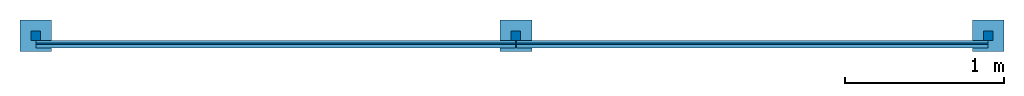
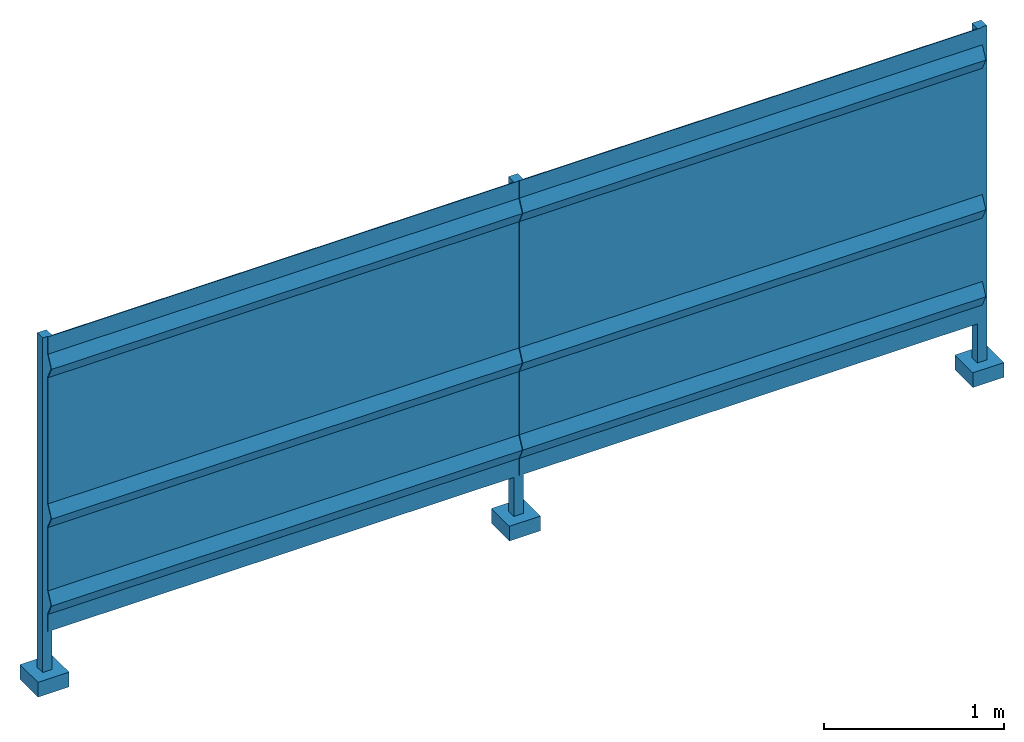
# One storey: 1 wall.
"""IFC2X3 building model written with IfcOpenShell, lengths in millimetres."""

from ifc_helpers import new_model, entity, si_unit, converted_unit, derived_unit, direction, frame, origin, place, context, subcontext, project, spatial, faceted_brep, material, type_object, element, save


model = new_model("IFC2X3")

# Units and contexts
model_context = context("Model", 3, precision=0.01, world=origin(), true_north=direction((6.12303176911189e-17, 1.0)))
body_context = subcontext(model_context, "Body", "Model", "MODEL_VIEW")
ifc_project = project(units=[si_unit("LENGTHUNIT", "METRE", prefix="MILLI"), si_unit("AREAUNIT", "SQUARE_METRE"), si_unit("VOLUMEUNIT", "CUBIC_METRE"), converted_unit("PLANEANGLEUNIT", "DEGREE", entity("IfcRatioMeasure", 0.0174532925199433), si_unit("PLANEANGLEUNIT", "RADIAN"), dimensions=[0, 0, 0, 0, 0, 0, 0]), si_unit("MASSUNIT", "GRAM", prefix="KILO"), derived_unit("MASSDENSITYUNIT", [(si_unit("MASSUNIT", "GRAM", prefix="KILO"), 1), (si_unit("LENGTHUNIT", "METRE"), -3)]), si_unit("TIMEUNIT", "SECOND"), si_unit("FREQUENCYUNIT", "HERTZ"), si_unit("THERMODYNAMICTEMPERATUREUNIT", "DEGREE_CELSIUS"), derived_unit("THERMALTRANSMITTANCEUNIT", [(si_unit("MASSUNIT", "GRAM", prefix="KILO"), 1), (si_unit("THERMODYNAMICTEMPERATUREUNIT", "KELVIN"), -1), (si_unit("TIMEUNIT", "SECOND"), -3)]), derived_unit("VOLUMETRICFLOWRATEUNIT", [(si_unit("LENGTHUNIT", "METRE"), 3), (si_unit("TIMEUNIT", "SECOND"), -1)]), si_unit("ELECTRICCURRENTUNIT", "AMPERE"), si_unit("ELECTRICVOLTAGEUNIT", "VOLT"), si_unit("POWERUNIT", "WATT"), si_unit("FORCEUNIT", "NEWTON", prefix="KILO"), si_unit("ILLUMINANCEUNIT", "LUX"), si_unit("LUMINOUSFLUXUNIT", "LUMEN"), si_unit("LUMINOUSINTENSITYUNIT", "CANDELA"), derived_unit("USERDEFINED", [(si_unit("MASSUNIT", "GRAM", prefix="KILO"), -1), (si_unit("LENGTHUNIT", "METRE"), -2), (si_unit("TIMEUNIT", "SECOND"), 3), (si_unit("LUMINOUSFLUXUNIT", "LUMEN"), 1)]), derived_unit("LINEARVELOCITYUNIT", [(si_unit("LENGTHUNIT", "METRE"), 1), (si_unit("TIMEUNIT", "SECOND"), -1)]), si_unit("PRESSUREUNIT", "PASCAL"), derived_unit("USERDEFINED", [(si_unit("LENGTHUNIT", "METRE"), -2), (si_unit("MASSUNIT", "GRAM", prefix="KILO"), 1), (si_unit("TIMEUNIT", "SECOND"), -2)])], contexts=[model_context])

# Site, building, storey
site_placement = place(None, origin())
site = spatial("IfcSite", under=ifc_project, at=site_placement, CompositionType="ELEMENT")
building_placement = place(site_placement, origin())
building = spatial("IfcBuilding", under=site, at=building_placement, CompositionType="ELEMENT")
storey_placement = place(building_placement, origin())
storey = spatial("IfcBuildingStorey", under=building, at=storey_placement, Name="Level 1", CompositionType="ELEMENT", Elevation=0.0)

# Wall
ifc_material = material()
wall_type = type_object("IfcWallType", PredefinedType="NOTDEFINED", material=ifc_material)
wall_placement = place(storey_placement, frame((-100.0, -100.0, -300.0)))
element("IfcWall", 1, at=wall_placement, inside=storey, type_object=wall_type, material=ifc_material, context=body_context, shape_type="Brep", body=[
    faceted_brep([(3123.0, 64.0, 487.0), (3123.0, 64.0, 370.0), (3123.0, 70.0, 370.0), (3123.0, 70.0, 488.368629060399), (3123.0, 31.6586527353121, 567.0), (3123.0, 70.0, 645.63137093946), (3123.0, 70.0, 1078.3686290604), (3123.0, 31.6586527353121, 1157.0), (3123.0, 70.0, 1235.63137093946), (3123.0, 70.0, 2094.3686290604), (3123.0, 31.6586527353121, 2173.0), (3123.0, 70.0, 2251.63137093946), (3123.0, 70.0, 2370.0), (3123.0, 64.0, 2370.0), (3123.0, 64.0, 2253.0), (3123.0, 25.0, 2173.0), (3123.0, 64.0, 2093.0), (3123.0, 64.0, 1237.0), (3123.0, 25.0, 1157.0), (3123.0, 64.0, 1077.0), (3123.0, 64.0, 647.0), (3123.0, 25.0, 567.0), (102.0, 64.0, 487.0), (102.0, 64.0, 370.0), (102.0, 70.0, 370.0), (102.0, 70.0, 488.368629060399), (102.0, 31.6586527353121, 567.0), (102.0, 70.0, 645.63137093946), (102.0, 70.0, 1078.3686290604), (102.0, 31.6586527353121, 1157.0), (102.0, 70.0, 1235.63137093946), (102.0, 70.0, 2094.3686290604), (102.0, 64.0, 2093.0), (102.0, 64.0, 1237.0), (102.0, 25.0, 1157.0), (102.0, 64.0, 1077.0), (102.0, 64.0, 647.0), (102.0, 25.0, 567.0), (102.0, 25.0, 2173.0), (102.0, 64.0, 2253.0), (102.0, 64.0, 2370.0), (102.0, 70.0, 2370.0), (102.0, 70.0, 2251.63137093946), (102.0, 31.6586527353121, 2173.0)], [[[0, 1, 2, 3, 4, 5, 6, 7, 8, 9, 10, 11, 12, 13, 14, 15, 16, 17, 18, 19, 20, 21]], [[1, 0, 22, 23]], [[2, 1, 23, 24]], [[3, 2, 24, 25]], [[4, 3, 25, 26]], [[5, 4, 26, 27]], [[6, 5, 27, 28]], [[7, 6, 28, 29]], [[8, 7, 29, 30]], [[9, 8, 30, 31]], [[17, 16, 32, 33]], [[18, 17, 33, 34]], [[19, 18, 34, 35]], [[20, 19, 35, 36]], [[21, 20, 36, 37]], [[0, 21, 37, 22]], [[22, 37, 36, 35, 34, 33, 32, 38, 39, 40, 41, 42, 43, 31, 30, 29, 28, 27, 26, 25, 24, 23]], [[11, 10, 43, 42]], [[12, 11, 42, 41]], [[13, 12, 41, 40]], [[14, 13, 40, 39]], [[15, 14, 39, 38]], [[10, 9, 31, 43]], [[16, 15, 38, 32]]]),
    faceted_brep([(200.0, 200.0, 100.0), (0.0, 200.0, 100.0), (0.0, 0.0, 100.0), (200.0, 0.0, 100.0), (200.0, 200.0, 0.0), (200.0, 0.0, 0.0), (0.0, 0.0, 0.0), (0.0, 200.0, 0.0)], [[[0, 1, 2, 3]], [[4, 5, 6, 7]], [[1, 0, 4, 7]], [[2, 1, 7, 6]], [[3, 2, 6, 5]], [[0, 3, 5, 4]]]),
    faceted_brep([(130.0, 130.0, 100.0), (130.0, 70.0, 100.0), (70.0, 70.0, 100.0), (70.0, 130.0, 100.0), (130.0, 130.0, 2370.0), (130.0, 70.0, 2370.0), (70.0, 70.0, 2370.0), (70.0, 130.0, 2370.0)], [[[0, 1, 2, 3]], [[4, 5, 1, 0]], [[5, 6, 2, 1]], [[6, 7, 3, 2]], [[7, 4, 0, 3]], [[4, 7, 6, 5]]]),
    faceted_brep([(3225.0, 200.0, 100.0), (3025.0, 200.0, 100.0), (3025.0, 0.0, 100.0), (3225.0, 0.0, 100.0), (3225.0, 200.0, 0.0), (3225.0, 0.0, 0.0), (3025.0, 0.0, 0.0), (3025.0, 200.0, 0.0)], [[[0, 1, 2, 3]], [[4, 5, 6, 7]], [[1, 0, 4, 7]], [[2, 1, 7, 6]], [[3, 2, 6, 5]], [[0, 3, 5, 4]]]),
    faceted_brep([(3155.0, 130.0, 100.0), (3155.0, 70.0, 100.0), (3095.0, 70.0, 100.0), (3095.0, 130.0, 100.0), (3155.0, 130.0, 2370.0), (3155.0, 70.0, 2370.0), (3095.0, 70.0, 2370.0), (3095.0, 130.0, 2370.0)], [[[0, 1, 2, 3]], [[4, 5, 1, 0]], [[5, 6, 2, 1]], [[6, 7, 3, 2]], [[7, 4, 0, 3]], [[4, 7, 6, 5]]]),
    faceted_brep([(6098.0, 64.0, 487.0), (6098.0, 64.0, 370.0), (6098.0, 70.0, 370.0), (6098.0, 70.0, 488.368629060376), (6098.0, 31.6586527352925, 567.0), (6098.0, 70.0, 645.631370939437), (6098.0, 70.0, 1078.36862906038), (6098.0, 31.6586527352925, 1157.0), (6098.0, 70.0, 1235.63137093943), (6098.0, 70.0, 2094.36862906038), (6098.0, 31.6586527352925, 2173.0), (6098.0, 70.0, 2251.63137093944), (6098.0, 70.0, 2370.0), (6098.0, 64.0, 2370.0), (6098.0, 64.0, 2253.0), (6098.0, 25.0, 2173.0), (6098.0, 64.0, 2093.0), (6098.0, 64.0, 1237.0), (6098.0, 25.0, 1157.0), (6098.0, 64.0, 1077.0), (6098.0, 64.0, 647.0), (6098.0, 25.0, 567.0), (3127.0, 64.0, 487.0), (3127.0, 64.0, 370.0), (3127.0, 70.0, 370.0), (3127.0, 70.0, 488.368629060376), (3127.0, 31.6586527352925, 567.0), (3127.0, 70.0, 645.631370939437), (3127.0, 70.0, 1078.36862906038), (3127.0, 31.6586527352925, 1157.0), (3127.0, 70.0, 1235.63137093943), (3127.0, 70.0, 2094.36862906038), (3127.0, 64.0, 2093.0), (3127.0, 64.0, 1237.0), (3127.0, 25.0, 1157.0), (3127.0, 64.0, 1077.0), (3127.0, 64.0, 647.0), (3127.0, 25.0, 567.0), (3127.0, 25.0, 2173.0), (3127.0, 64.0, 2253.0), (3127.0, 64.0, 2370.0), (3127.0, 70.0, 2370.0), (3127.0, 70.0, 2251.63137093944), (3127.0, 31.6586527352925, 2173.0)], [[[0, 1, 2, 3, 4, 5, 6, 7, 8, 9, 10, 11, 12, 13, 14, 15, 16, 17, 18, 19, 20, 21]], [[1, 0, 22, 23]], [[2, 1, 23, 24]], [[3, 2, 24, 25]], [[4, 3, 25, 26]], [[5, 4, 26, 27]], [[6, 5, 27, 28]], [[7, 6, 28, 29]], [[8, 7, 29, 30]], [[9, 8, 30, 31]], [[17, 16, 32, 33]], [[18, 17, 33, 34]], [[19, 18, 34, 35]], [[20, 19, 35, 36]], [[21, 20, 36, 37]], [[0, 21, 37, 22]], [[22, 37, 36, 35, 34, 33, 32, 38, 39, 40, 41, 42, 43, 31, 30, 29, 28, 27, 26, 25, 24, 23]], [[11, 10, 43, 42]], [[12, 11, 42, 41]], [[13, 12, 41, 40]], [[14, 13, 40, 39]], [[15, 14, 39, 38]], [[10, 9, 31, 43]], [[16, 15, 38, 32]]]),
    faceted_brep([(6200.0, 200.0, 100.0), (6000.0, 200.0, 100.0), (6000.0, 0.0, 100.0), (6200.0, 0.0, 100.0), (6200.0, 200.0, 0.0), (6200.0, 0.0, 0.0), (6000.0, 0.0, 0.0), (6000.0, 200.0, 0.0)], [[[0, 1, 2, 3]], [[4, 5, 6, 7]], [[1, 0, 4, 7]], [[2, 1, 7, 6]], [[3, 2, 6, 5]], [[0, 3, 5, 4]]]),
    faceted_brep([(6130.0, 130.0, 100.0), (6130.0, 70.0, 100.0), (6070.0, 70.0, 100.0), (6070.0, 130.0, 100.0), (6130.0, 130.0, 2370.0), (6130.0, 70.0, 2370.0), (6070.0, 70.0, 2370.0), (6070.0, 130.0, 2370.0)], [[[0, 1, 2, 3]], [[4, 5, 1, 0]], [[5, 6, 2, 1]], [[6, 7, 3, 2]], [[7, 4, 0, 3]], [[4, 7, 6, 5]]]),
])

save(model, "model.ifc")
